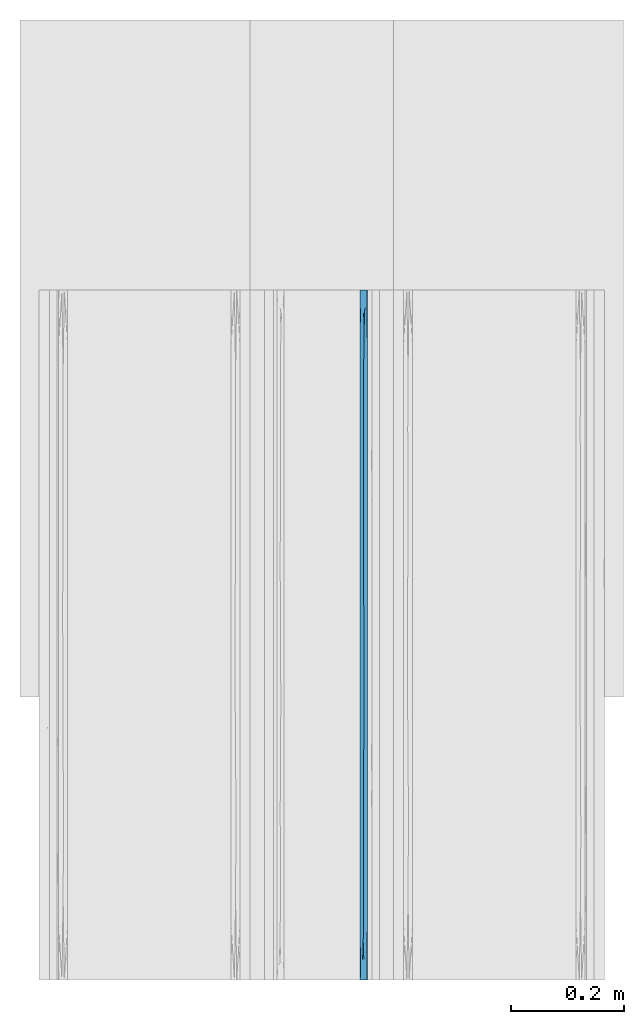
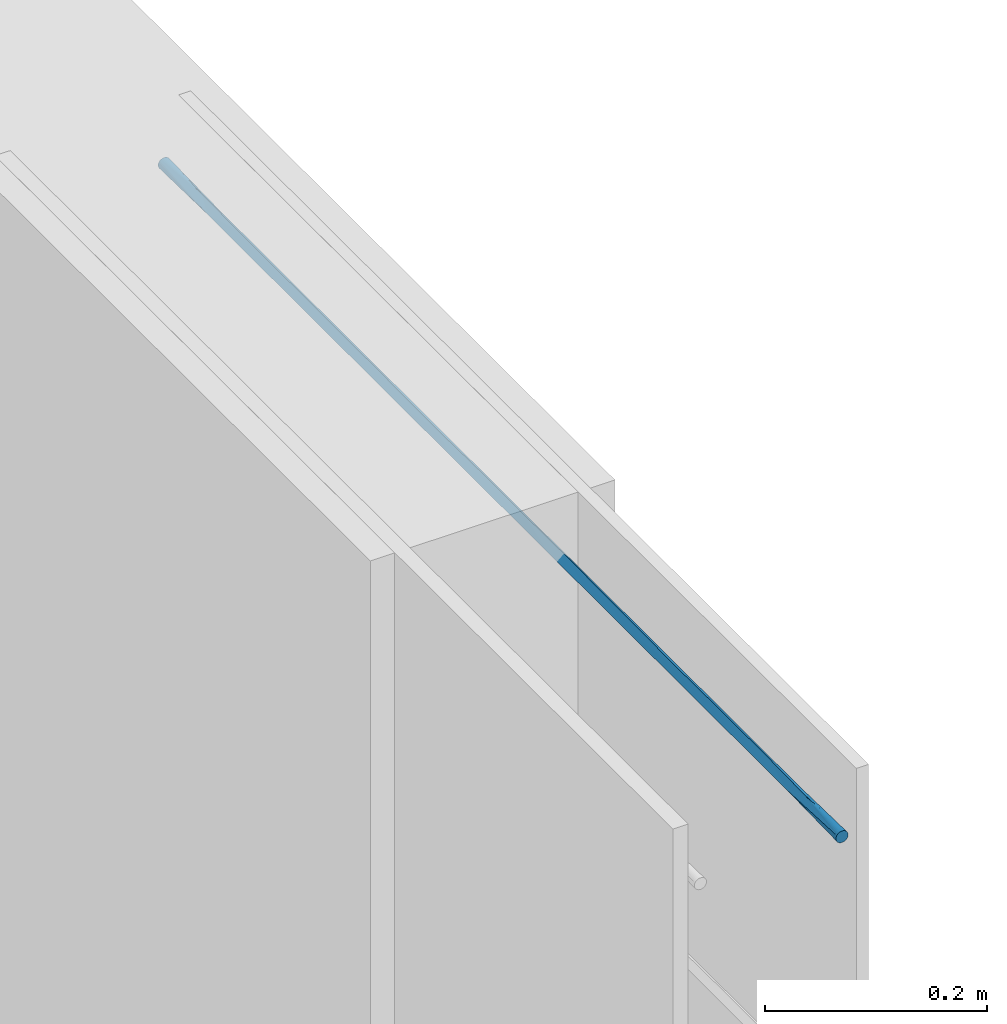
# One storey, part 10 of 10: 1 wall.
"""IFC2X3 building model written with IfcOpenShell, lengths in feet."""

import ifcopenshell
import ifcopenshell.guid

model = None  # the IFC model being written
_history = None  # IfcOwnerHistory: only IFC2X3 demands one
_inside = {}  # id of a spatial element -> (the spatial element, [elements in it])
_under = {}  # id of a project, library or spatial element -> (it, [spatial elements below it])
_declared = {}  # id of a project -> (the project, [libraries it declares])
_typed = {}  # id of a type object -> (the type object, [elements of that type])
_made_of = {}  # id of a material, layer set ... -> (it, [elements and type objects made of it])


def new_model(schema):
    """Start an empty IFC model of exactly this schema.

    Asked for "IFC4X3", IfcOpenShell would pick the latest addendum, in which some entities
    have other attributes; the version numbers below select the first issue.
    IFC2X3 requires an IfcOwnerHistory on every rooted entity: one is made here for all.
    """
    global model, _history
    if schema == "IFC4X3":
        model = ifcopenshell.file(schema_version=(4, 3, 0, 0))
    else:
        model = ifcopenshell.file(schema=schema)
    _inside.clear()
    _under.clear()
    _declared.clear()
    _typed.clear()
    _made_of.clear()
    _history = None
    if model.schema == "IFC2X3":
        org = make("IfcOrganization", Name="unknown")
        user = make(
            "IfcPersonAndOrganization",
            ThePerson=make("IfcPerson", FamilyName="unknown"),
            TheOrganization=org,
        )
        app = make(
            "IfcApplication",
            ApplicationDeveloper=org,
            Version="unknown",
            ApplicationFullName="unknown",
            ApplicationIdentifier="unknown",
        )
        _history = make(
            "IfcOwnerHistory",
            OwningUser=user,
            OwningApplication=app,
            ChangeAction="ADDED",
            CreationDate=0,
        )
    return model


def make(cls, **values):
    """One entity of the class cls with the attributes given. An attribute that is None is left unset."""
    return model.create_entity(
        cls, **{name: value for name, value in values.items() if value is not None}
    )


def entity(cls, *values):
    """Any entity or typed value of the class cls, its attributes in the order of the schema. None: left unset."""
    e = model.create_entity(cls)
    for i, value in enumerate(values):
        if value is not None:
            e[i] = value
    return e


def rooted(cls, **values):
    """An entity with a GlobalId (a new one), such as an element, a storey or a relation."""
    return make(cls, GlobalId=ifcopenshell.guid.new(), OwnerHistory=_history, **values)


def si_unit(unit_type, name, prefix=None):
    """IfcSIUnit, for example si_unit("LENGTHUNIT", "METRE", prefix="MILLI")."""
    return make("IfcSIUnit", UnitType=unit_type, Prefix=prefix, Name=name)


def converted_unit(unit_type, name, factor, base, dimensions=None, offset=None):
    """IfcConversionBasedUnit, such as the inch: factor (a typed value) times the base unit."""
    return make(
        "IfcConversionBasedUnit"
        if offset is None
        else "IfcConversionBasedUnitWithOffset",
        ConversionOffset=offset,
        Dimensions=None
        if dimensions is None
        else entity("IfcDimensionalExponents", *dimensions),
        UnitType=unit_type,
        Name=name,
        ConversionFactor=make(
            "IfcMeasureWithUnit", ValueComponent=factor, UnitComponent=base
        ),
    )


def derived_unit(unit_type, elements):
    """IfcDerivedUnit: a product of units, each with its exponent."""
    return make(
        "IfcDerivedUnit",
        Elements=[
            make("IfcDerivedUnitElement", Unit=unit, Exponent=power)
            for unit, power in elements
        ],
        UnitType=unit_type,
    )


def assignment(units):
    """IfcUnitAssignment: the units of a project."""
    return None if units is None else make("IfcUnitAssignment", Units=units)


def point(xyz):
    """IfcCartesianPoint."""
    return None if xyz is None else make("IfcCartesianPoint", Coordinates=xyz)


def direction(xyz):
    """IfcDirection."""
    return None if xyz is None else make("IfcDirection", DirectionRatios=xyz)


def frame(location, z_axis=None, x_axis=None):
    """IfcAxis2Placement3D, a coordinate frame: its origin and axes. An axis left out is left unset."""
    return make(
        "IfcAxis2Placement3D",
        Location=point(location),
        Axis=direction(z_axis),
        RefDirection=direction(x_axis),
    )


def origin():
    """The frame at (0, 0, 0) with its axes left unset."""
    return frame((0.0, 0.0, 0.0))


def place(relative_to, where):
    """IfcLocalPlacement: puts the frame where relative to a parent placement (None: the world)."""
    return make(
        "IfcLocalPlacement", PlacementRelTo=relative_to, RelativePlacement=where
    )


def context(
    kind, dimensions, precision=None, world=None, true_north=None, identifier=None
):
    """IfcGeometricRepresentationContext, for example the 3D "Model" context."""
    return make(
        "IfcGeometricRepresentationContext",
        ContextIdentifier=identifier,
        ContextType=kind,
        CoordinateSpaceDimension=dimensions,
        Precision=precision,
        WorldCoordinateSystem=world,
        TrueNorth=true_north,
    )


def subcontext(parent, identifier, kind, view, scale=None):
    """IfcGeometricRepresentationSubContext, for example "Body" below "Model"."""
    return make(
        "IfcGeometricRepresentationSubContext",
        ContextIdentifier=identifier,
        ContextType=kind,
        ParentContext=parent,
        TargetScale=scale,
        TargetView=view,
    )


def project(units=None, contexts=None):
    """IfcProject with its units and contexts."""
    return rooted(
        "IfcProject",
        Name="project",
        RepresentationContexts=contexts,
        UnitsInContext=assignment(units),
    )


def spatial(cls, under=None, at=None, **own):
    """A site, building, storey or space (cls), placed at a placement, below another one or the project."""
    s = rooted(cls, ObjectPlacement=at, **own)
    if under is not None:
        _under.setdefault(under.id(), (under, []))[1].append(s)
    return s


def faces_of(points, faces, orient=None, outer=None):
    """IfcFace entities. A face is a list of loops; a loop is a list of indices into points, from 0.

    orient and outer hold one flag for each loop. By default every Orientation is true, the
    first loop of a face is its IfcFaceOuterBound and the others are IfcFaceBound.
    """
    made = []
    for i, loops in enumerate(faces):
        bounds = []
        for j, loop in enumerate(loops):
            is_outer = j == 0 if outer is None else outer[i][j]
            bounds.append(
                make(
                    "IfcFaceOuterBound" if is_outer else "IfcFaceBound",
                    Bound=make("IfcPolyLoop", Polygon=[points[k] for k in loop]),
                    Orientation=True if orient is None else orient[i][j],
                )
            )
        made.append(make("IfcFace", Bounds=bounds))
    return made


def faceted_brep(points, faces, orient=None, outer=None, voids=None):
    """IfcFacetedBrep: a solid bounded by flat faces; with voids (closed shells), ...WithVoids."""
    shared = [point(p) for p in points]
    hull = make("IfcClosedShell", CfsFaces=faces_of(shared, faces, orient, outer))
    if voids is None:
        return make("IfcFacetedBrep", Outer=hull)
    return make(
        "IfcFacetedBrepWithVoids",
        Outer=hull,
        Voids=[
            make(cls, CfsFaces=faces_of(shared, fs, o, b)) for cls, fs, o, b in voids
        ],
    )


def shape(context_of_items, identifier, shape_type, items):
    """IfcShapeRepresentation: the items that make up one representation, for example the "Body"."""
    return make(
        "IfcShapeRepresentation",
        ContextOfItems=context_of_items,
        RepresentationIdentifier=identifier,
        RepresentationType=shape_type,
        Items=items,
    )


def material(Name=None, Category=None):
    """IfcMaterial."""
    return make("IfcMaterial", Name=Name, Category=Category)


def made_of(thing, what):
    """Note that an element or type object is made of a material, layer set ...; save() writes the relation."""
    if what is not None:
        _made_of.setdefault(what.id(), (what, []))[1].append(thing)
    return thing


def type_object(cls, material=None, **own):
    """A type object (cls), such as IfcWallType, which elements share."""
    return made_of(rooted(cls, **own), material)


def element(
    cls,
    number,
    at=None,
    inside=None,
    cuts=None,
    type_object=None,
    material=None,
    context=None,
    identifier="Body",
    shape_type=None,
    held_by="IfcProductDefinitionShape",
    body=None,
    shapes=None,
    **own,
):
    """One element of the class cls, such as IfcWall. Its Tag is "e" and its number.

    at: its placement. inside: the storey or other place that contains it. cuts: it is an
    opening in that element (IfcRelVoidsElement). A single representation is given by context,
    identifier, shape_type and body (its items); several are given by shapes. held_by: the class
    of the entity that holds the representations. save() writes the other relations.
    """
    e = rooted(cls, Tag="e%d" % number, ObjectPlacement=at, **own)
    if body is not None:
        shapes = [shape(context, identifier, shape_type, body)]
    if shapes is not None:
        e.Representation = make(held_by, Representations=shapes)
    if inside is not None:
        _inside.setdefault(inside.id(), (inside, []))[1].append(e)
    if cuts is not None:
        rooted(
            "IfcRelVoidsElement", RelatingBuildingElement=cuts, RelatedOpeningElement=e
        )
    if type_object is not None:
        _typed.setdefault(type_object.id(), (type_object, []))[1].append(e)
    return made_of(e, material)


def aggregate(whole, parts):
    """IfcRelAggregates: a whole, such as a stair, and the parts it consists of."""
    return rooted("IfcRelAggregates", RelatingObject=whole, RelatedObjects=parts)


def save(model, path):
    """Write the relations noted so far, then the file.

    IfcRelAggregates (storeys below a building ...), IfcRelContainedInSpatialStructure (elements
    in a storey), IfcRelDefinesByType, IfcRelAssociatesMaterial and IfcRelDeclares: one each for
    every whole, place, type object, material and project.
    """
    for whole, parts in _under.values():
        aggregate(whole, parts)
    for where, things in _inside.values():
        rooted(
            "IfcRelContainedInSpatialStructure",
            RelatedElements=things,
            RelatingStructure=where,
        )
    for kind, things in _typed.values():
        rooted("IfcRelDefinesByType", RelatedObjects=things, RelatingType=kind)
    for what, things in _made_of.values():
        rooted("IfcRelAssociatesMaterial", RelatedObjects=things, RelatingMaterial=what)
    for by, libraries in _declared.values():
        rooted("IfcRelDeclares", RelatingContext=by, RelatedDefinitions=libraries)
    model.write(path)


model = new_model("IFC2X3")

# Units and contexts
model_context = context("Model", 3, precision=0.0001, world=origin(), true_north=direction((6.12303176911189e-17, 1.0)))
body_context = subcontext(model_context, "Body", "Model", "MODEL_VIEW")
ifc_project = project(units=[converted_unit("LENGTHUNIT", "FOOT", entity("IfcRatioMeasure", 0.3048), si_unit("LENGTHUNIT", "METRE"), dimensions=[1, 0, 0, 0, 0, 0, 0]), converted_unit("AREAUNIT", "SQUARE FOOT", entity("IfcRatioMeasure", 0.09290304), si_unit("AREAUNIT", "SQUARE_METRE"), dimensions=[2, 0, 0, 0, 0, 0, 0]), converted_unit("VOLUMEUNIT", "CUBIC FOOT", entity("IfcRatioMeasure", 0.028316846592), si_unit("VOLUMEUNIT", "CUBIC_METRE"), dimensions=[3, 0, 0, 0, 0, 0, 0]), converted_unit("PLANEANGLEUNIT", "DEGREE", entity("IfcRatioMeasure", 0.0174532925199433), si_unit("PLANEANGLEUNIT", "RADIAN"), dimensions=[0, 0, 0, 0, 0, 0, 0]), si_unit("MASSUNIT", "GRAM", prefix="KILO"), derived_unit("MASSDENSITYUNIT", [(si_unit("MASSUNIT", "GRAM", prefix="KILO"), 1), (si_unit("LENGTHUNIT", "METRE"), -3)]), si_unit("TIMEUNIT", "SECOND"), si_unit("FREQUENCYUNIT", "HERTZ"), si_unit("THERMODYNAMICTEMPERATUREUNIT", "DEGREE_CELSIUS"), derived_unit("THERMALTRANSMITTANCEUNIT", [(si_unit("MASSUNIT", "GRAM", prefix="KILO"), 1), (si_unit("THERMODYNAMICTEMPERATUREUNIT", "KELVIN"), -1), (si_unit("TIMEUNIT", "SECOND"), -3)]), derived_unit("VOLUMETRICFLOWRATEUNIT", [(si_unit("LENGTHUNIT", "METRE"), 3), (si_unit("TIMEUNIT", "SECOND"), -1)]), si_unit("ELECTRICCURRENTUNIT", "AMPERE"), si_unit("ELECTRICVOLTAGEUNIT", "VOLT"), si_unit("POWERUNIT", "WATT"), si_unit("FORCEUNIT", "NEWTON", prefix="KILO"), si_unit("ILLUMINANCEUNIT", "LUX"), si_unit("LUMINOUSFLUXUNIT", "LUMEN"), si_unit("LUMINOUSINTENSITYUNIT", "CANDELA"), derived_unit("USERDEFINED", [(si_unit("MASSUNIT", "GRAM", prefix="KILO"), -1), (si_unit("LENGTHUNIT", "METRE"), -2), (si_unit("TIMEUNIT", "SECOND"), 3), (si_unit("LUMINOUSFLUXUNIT", "LUMEN"), 1)]), derived_unit("LINEARVELOCITYUNIT", [(si_unit("LENGTHUNIT", "METRE"), 1), (si_unit("TIMEUNIT", "SECOND"), -1)]), si_unit("PRESSUREUNIT", "PASCAL"), derived_unit("USERDEFINED", [(si_unit("LENGTHUNIT", "METRE"), -2), (si_unit("MASSUNIT", "GRAM", prefix="KILO"), 1), (si_unit("TIMEUNIT", "SECOND"), -2)])], contexts=[model_context])

# Site, building, storey
site_placement = place(None, origin())
site = spatial("IfcSite", under=ifc_project, at=site_placement, CompositionType="ELEMENT")
building_placement = place(site_placement, origin())
building = spatial("IfcBuilding", under=site, at=building_placement, CompositionType="ELEMENT")
storey_placement = place(building_placement, frame((0.0, 0.0, 11.2604166666667)))
storey = spatial("IfcBuildingStorey", under=building, at=storey_placement, Name="2ND FLOOR", CompositionType="ELEMENT", Elevation=11.2604166666667)

# Wall
ifc_material = material()
wall_type = type_object("IfcWallType", Name="Generic Models 1", PredefinedType="NOTDEFINED", material=ifc_material)
wall_placement = place(storey_placement, frame((1429.90087203322, 0.249999999977767, 6.90503341074841), z_axis=(0.0, 0.0, 1.0), x_axis=(0.0, 1.0, 0.0)))
element("IfcWall", 1, at=wall_placement, inside=storey, type_object=wall_type, material=ifc_material, Name="Generic Models 245:Generic Models 1", ObjectType="Generic Models 245:Generic Models 1", context=body_context, shape_type="Brep", body=[
    faceted_brep([(4.0, -0.0262253967728157, 0.0409567880476871), (4.0, -0.03125, 0.0388755292455087), (4.0, -0.0355647246078661, 0.0355647246080508), (4.0, -0.038875529245388, 0.03125), (4.0, -0.0409567880476516, 0.0262253967729684), (4.0, -0.0416666666665151, 0.0208333333333321), (4.0, -0.0409567880476516, 0.0154412698936959), (4.0, -0.038875529245388, 0.0104166666666643), (4.0, -0.0355647246078661, 0.00610194205861347), (4.0, -0.03125, 0.00279113742115555), (4.0, -0.0262253967728157, 0.0007098786189772), (4.0, -0.0208333333332575, 0.0), (4.0, -0.0154412698936994, 0.0007098786189772), (4.0, -0.0104166666665151, 0.00279113742115555), (4.0, -0.006101942058649, 0.00610194205861347), (4.0, -0.00279113742112713, 0.0104166666666643), (4.0, -0.000709878618863513, 0.0154412698936959), (4.0, 0.0, 0.0208333333333321), (4.0, -0.000709878618863513, 0.0262253967729684), (4.0, -0.00279113742112713, 0.03125), (4.0, -0.006101942058649, 0.0355647246080508), (4.0, -0.0104166666665151, 0.0388755292455087), (4.0, -0.0154412698936994, 0.0409567880476871), (4.0, -0.0208333333332575, 0.0416666666666643), (0.0, -0.0262253967728157, 0.000709878618984305), (0.0, -0.03125, 0.00279113742116266), (0.0, -0.0355647246078661, 0.00610194205862058), (0.0, -0.038875529245388, 0.0104166666666714), (0.0, -0.0409567880476516, 0.015441269893703), (0.0, -0.0416666666665151, 0.0208333333333393), (0.0, -0.0409567880476516, 0.0262253967729755), (0.0, -0.038875529245388, 0.0312500000000071), (0.0, -0.0355647246078661, 0.0355647246080579), (0.0, -0.03125, 0.0388755292455159), (0.0, -0.0262253967728157, 0.0409567880476942), (0.0, -0.0208333333332575, 0.0416666666666714), (0.0, -0.0154412698936994, 0.0409567880476942), (0.0, -0.0104166666665151, 0.0388755292455159), (0.0, -0.006101942058649, 0.0355647246080579), (0.0, -0.00279113742112713, 0.0312500000000071), (0.0, -0.000709878618863513, 0.0262253967729755), (0.0, 0.0, 0.0208333333333393), (0.0, -0.000709878618863513, 0.015441269893703), (0.0, -0.00279113742112713, 0.0104166666666714), (0.0, -0.006101942058649, 0.00610194205862058), (0.0, -0.0104166666665151, 0.00279113742116266), (0.0, -0.0154412698936994, 0.000709878618984305), (0.0, -0.0208333333332575, 0.0), (2.14388402114763, -0.0200322252712795, 1.54082770080777e-05), (1.8749999873482, -0.0201164472750861, 1.23378682417297e-05), (2.0, 0.0, 0.0208333333333357), (0.2209945797568, -0.0235526290068719, 0.000178232055045413), (3.78349365025041, -0.0181140376355415, 0.000178232058182459), (0.288675181168509, -0.0416666666667425, 0.0208333333333393), (2.55662427510468, -0.0416666666667425, 0.0208333333333357), (2.39350545093993, -0.0230795128859427, 0.000121441696034452), (2.72964779378728, -0.0208333333494011, 0.0), (3.71132487914723, -0.0416666666665151, 0.0208333333333321), (0.959427115258349, -0.0225483860315308, 7.07137486202214e-05), (0.78867513369125, 0.0, 0.0208333333333393), (0.845299480274044, 0.0, 0.0208333333333393), (1.0, 0.0, 0.0208333333333393), (1.05662434259908, 0.0, 0.0208333333333357), (1.25, 0.0, 0.0208333333333357), (1.75, 0.0, 0.0208333333333357), (1.62498580610317, -0.0185830665252524, 0.000121885361959784), (3.71132486630875, 0.0, 0.0208333333333321), (0.28867513369125, 0.0, 0.0208333333333393), (0.577350267382501, 0.0, 0.0208333333333393), (0.711324858555642, -0.0208333333287101, 0.0), (0.44198915950752, -0.0208333333268911, 0.0), (3.13397456595189, 0.0, 0.0208333333333357), (3.42264969964314, 0.0, 0.0208333333333321), (3.27831213705374, -0.0208333333389419, 0.0), (2.98963700310718, -0.0208333333653172, 0.0), (2.63397456595189, 0.0, 0.0208333333333357), (2.84529943226064, 0.0, 0.0208333333333357), (3.56698727175129, -0.0208333335056068, 0.0), (3.42264975829447, -0.0416666666662877, 0.0208333333333321), (3.1339746374417, -0.0416666666665151, 0.0208333333333357), (2.84529945627319, -0.0416666666662877, 0.0208333333333321), (2.6339745906388, -0.0416666666665151, 0.0208333333333357), (0.845299486431061, -0.0416666666665151, 0.0208333333333393), (0.788675136453734, -0.0416666666665151, 0.0208333333333357), (0.577350302021276, -0.0416666666665151, 0.0208333333333393), (1.97927407112088, 0.0, 0.0208333333333357), (1.97927403339915, -0.0416666666665151, 0.0208333333333357), (2.26794915425192, -0.0416666666665151, 0.0208333333333357), (2.21132486354627, -0.0416666666665151, 0.0208333333333357), (2.0, -0.0416666666665151, 0.0208333333333357), (2.21132486630875, 0.0, 0.0208333333333357), (2.26794921266759, 0.0, 0.0208333333333357), (2.42264969964314, 0.0, 0.0208333333333357), (2.55662432324038, 0.0, 0.0208333333333357), (1.75, -0.0416666666665151, 0.0208333333333357), (1.69059891254638, -0.0416666666665151, 0.0208333333333357), (1.47927402585968, -0.0416666666665151, 0.0208333333333357), (1.3749999905963, -0.0202049447002537, 9.47909105519784e-06), (2.42264972709253, -0.0416666666665151, 0.0208333333333357), (1.26794920492411, 0.0, 0.0208333333333357), (1.47927406724915, 0.0, 0.0208333333333357), (1.5, 0.0, 0.0208333333333357), (1.26794919948872, -0.0416666666665151, 0.0208333333333357), (1.25, -0.0416666666665151, 0.0208333333333357), (1.05662437311776, -0.0416666666662877, 0.0208333333333393), (1.0, -0.0416666666667425, 0.0208333333333393), (1.5, -0.0416666666665151, 0.0208333333333357), (1.69059892957418, 0.0, 0.0208333333333357), (2.14388402115656, -0.0216344413906882, 0.0416512583898339), (1.87499998744159, -0.0215502193923385, 0.0416543287983941), (0.220994579714599, -0.0181140376603253, 0.0414884346117397), (3.78349365012031, -0.0235526293449766, 0.0414884345671211), (2.3935054510086, -0.0185871537623825, 0.0415452249686439), (2.72964779341247, -0.0208333333278006, 0.0416666666666679), (0.959427115233259, -0.0191182806272536, 0.0415959529174224), (1.62498580618022, -0.023083600129894, 0.0415447813059444), (0.711324858513196, -0.0208333333348492, 0.0416666666666714), (0.441989159426871, -0.0208333333353039, 0.0416666666666714), (3.27831213726184, -0.0208333333314386, 0.0416666666666679), (2.9896370028857, -0.020833333322571, 0.0416666666666679), (3.56698727186825, -0.0208333332750499, 0.0416666666666679), (1.37499999066007, -0.0214617219517095, 0.0416571875760567)], [[[0, 1, 2, 3, 4, 5, 6, 7, 8, 9, 10, 11, 12, 13, 14, 15, 16, 17, 18, 19, 20, 21, 22, 23]], [[24, 25, 26, 27, 28, 29, 30, 31, 32, 33, 34, 35, 36, 37, 38, 39, 40, 41, 42, 43, 44, 45, 46, 47]], [[48, 49, 50]], [[24, 47, 51]], [[52, 9, 8]], [[27, 53, 28]], [[54, 55, 56]], [[51, 25, 24]], [[57, 7, 6]], [[57, 8, 7]], [[52, 13, 12]], [[6, 5, 57]], [[29, 28, 53]], [[58, 59, 60, 61, 62, 63]], [[64, 49, 65]], [[52, 14, 13]], [[66, 17, 16]], [[42, 41, 67]], [[42, 67, 43]], [[68, 59, 69, 70, 67]], [[71, 72, 73, 74, 56, 75, 76]], [[66, 77, 72]], [[78, 79, 80, 81, 54, 56, 74, 73]], [[69, 82, 83, 84, 53, 70]], [[78, 77, 57]], [[77, 52, 57]], [[49, 64, 85, 50]], [[48, 86, 49]], [[15, 66, 16]], [[47, 46, 51]], [[14, 52, 15]], [[70, 53, 51]], [[82, 69, 58]], [[69, 59, 58]], [[51, 26, 25]], [[44, 43, 67]], [[10, 52, 11]], [[45, 51, 46]], [[67, 70, 51]], [[44, 51, 45]], [[51, 27, 26]], [[51, 44, 67]], [[57, 52, 8]], [[48, 87, 88, 89, 86]], [[9, 52, 10]], [[55, 90, 91, 92, 93, 75]], [[53, 27, 51]], [[49, 86, 94, 95]], [[90, 55, 48]], [[73, 72, 77]], [[12, 11, 52]], [[73, 77, 78]], [[77, 66, 52]], [[66, 15, 52]], [[87, 48, 55]], [[55, 75, 56]], [[65, 96, 97]], [[55, 54, 98, 87]], [[97, 63, 99, 100, 101]], [[58, 102, 103, 104, 105, 82]], [[63, 97, 58]], [[97, 101, 65]], [[65, 95, 106, 96]], [[65, 101, 107, 64]], [[95, 65, 49]], [[102, 58, 97]], [[96, 102, 97]], [[48, 50, 90]], [[108, 109, 89]], [[36, 35, 110]], [[111, 21, 20]], [[39, 67, 40]], [[93, 112, 113]], [[110, 37, 36]], [[66, 19, 18]], [[66, 20, 19]], [[111, 1, 0]], [[18, 17, 66]], [[41, 40, 67]], [[114, 83, 82, 105, 104, 103]], [[94, 109, 115]], [[111, 2, 1]], [[57, 5, 4]], [[30, 29, 53]], [[30, 53, 31]], [[84, 83, 116, 117, 53]], [[79, 78, 118, 119, 113, 81, 80]], [[116, 83, 114]], [[72, 71, 76, 75, 93, 113, 119, 118]], [[116, 60, 59, 68, 67, 117]], [[72, 118, 120, 66]], [[120, 111, 66]], [[109, 94, 86, 89]], [[108, 85, 109]], [[3, 57, 4]], [[2, 111, 3]], [[34, 110, 35]], [[117, 67, 110]], [[60, 116, 114]], [[57, 120, 118, 78]], [[110, 38, 37]], [[32, 31, 53]], [[22, 111, 23]], [[33, 110, 34]], [[53, 117, 110]], [[32, 110, 33]], [[110, 39, 38]], [[110, 32, 53]], [[66, 111, 20]], [[108, 91, 90, 50, 85]], [[21, 111, 22]], [[112, 88, 87, 98, 54, 81]], [[67, 39, 110]], [[109, 85, 64, 107]], [[88, 112, 108]], [[0, 23, 111]], [[120, 57, 111]], [[57, 3, 111]], [[91, 108, 112]], [[112, 81, 113]], [[115, 100, 121]], [[112, 93, 92, 91]], [[121, 103, 102, 96, 106]], [[114, 99, 63, 62, 61, 60]], [[103, 121, 114]], [[121, 106, 115]], [[115, 107, 101, 100]], [[115, 106, 95, 94]], [[107, 115, 109]], [[99, 114, 121]], [[100, 99, 121]], [[108, 89, 88]]]),
])

save(model, "model.ifc")
